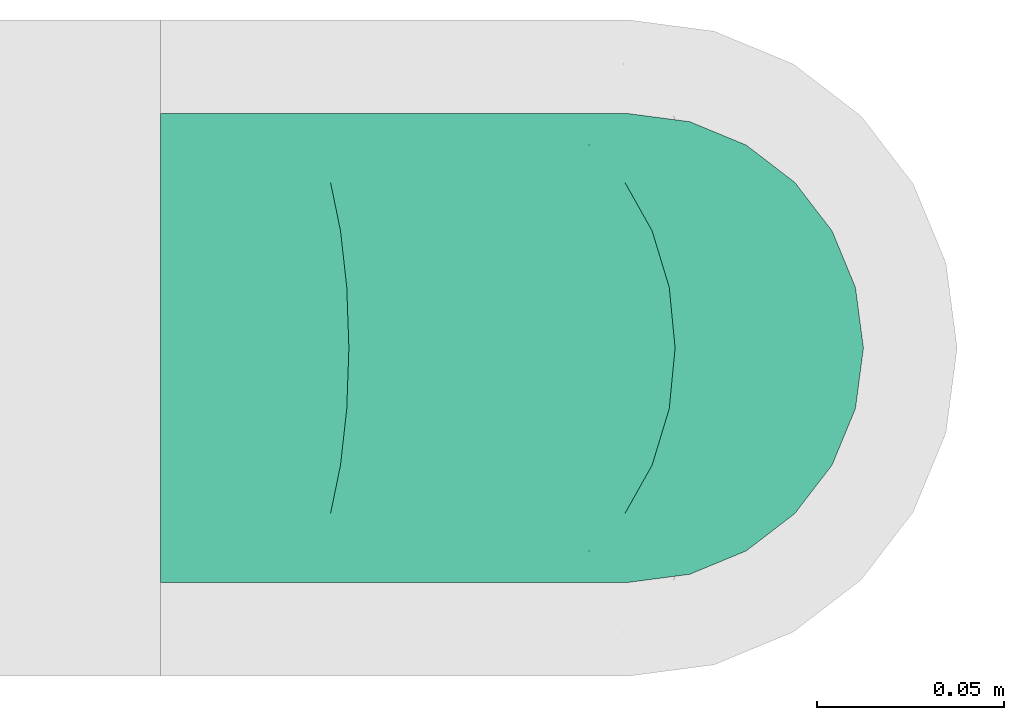
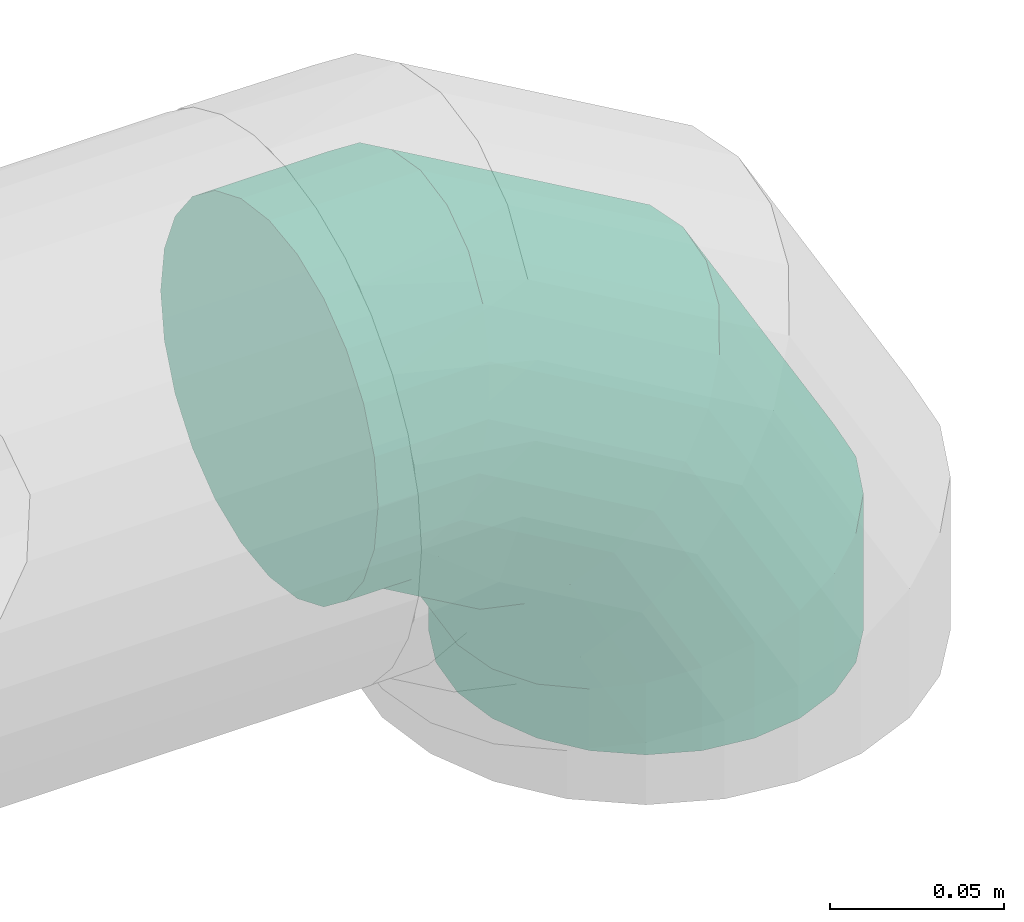
# One storey, part 84 of 97: 1 flow fitting.
"""IFC2X3 building model written with IfcOpenShell, lengths in millimetres."""

from ifc_helpers import new_model, entity, si_unit, converted_unit, derived_unit, direction, frame, origin, place, context, subcontext, project, spatial, faceted_brep, source, transform, mapped, material, type_object, type_shapes, element, save


model = new_model("IFC2X3")

# Units and contexts
model_context = context("Model", 3, precision=0.01, world=origin(), true_north=direction((6.12303176911189e-17, 1.0)))
body_context = subcontext(model_context, "Body", "Model", "MODEL_VIEW")
ifc_project = project(units=[si_unit("LENGTHUNIT", "METRE", prefix="MILLI"), si_unit("AREAUNIT", "SQUARE_METRE"), si_unit("VOLUMEUNIT", "CUBIC_METRE"), converted_unit("PLANEANGLEUNIT", "DEGREE", entity("IfcRatioMeasure", 0.0174532925199433), si_unit("PLANEANGLEUNIT", "RADIAN"), dimensions=[0, 0, 0, 0, 0, 0, 0]), si_unit("MASSUNIT", "GRAM", prefix="KILO"), derived_unit("MASSDENSITYUNIT", [(si_unit("MASSUNIT", "GRAM", prefix="KILO"), 1), (si_unit("LENGTHUNIT", "METRE"), -3)]), derived_unit("MOMENTOFINERTIAUNIT", [(si_unit("LENGTHUNIT", "METRE"), 4)]), si_unit("TIMEUNIT", "SECOND"), si_unit("FREQUENCYUNIT", "HERTZ"), si_unit("THERMODYNAMICTEMPERATUREUNIT", "DEGREE_CELSIUS"), derived_unit("THERMALTRANSMITTANCEUNIT", [(si_unit("MASSUNIT", "GRAM", prefix="KILO"), 1), (si_unit("THERMODYNAMICTEMPERATUREUNIT", "KELVIN"), -1), (si_unit("TIMEUNIT", "SECOND"), -3)]), derived_unit("VOLUMETRICFLOWRATEUNIT", [(si_unit("LENGTHUNIT", "METRE"), 3), (si_unit("TIMEUNIT", "SECOND"), -1)]), derived_unit("MASSFLOWRATEUNIT", [(si_unit("MASSUNIT", "GRAM", prefix="KILO"), 1), (si_unit("TIMEUNIT", "SECOND"), -1)]), derived_unit("ROTATIONALFREQUENCYUNIT", [(si_unit("TIMEUNIT", "SECOND"), -1)]), si_unit("ELECTRICCURRENTUNIT", "AMPERE"), si_unit("ELECTRICVOLTAGEUNIT", "VOLT"), si_unit("POWERUNIT", "WATT"), si_unit("FORCEUNIT", "NEWTON", prefix="KILO"), si_unit("ILLUMINANCEUNIT", "LUX"), si_unit("LUMINOUSFLUXUNIT", "LUMEN"), si_unit("LUMINOUSINTENSITYUNIT", "CANDELA"), derived_unit("USERDEFINED", [(si_unit("MASSUNIT", "GRAM", prefix="KILO"), -1), (si_unit("LENGTHUNIT", "METRE"), -2), (si_unit("TIMEUNIT", "SECOND"), 3), (si_unit("LUMINOUSFLUXUNIT", "LUMEN"), 1)]), derived_unit("LINEARVELOCITYUNIT", [(si_unit("LENGTHUNIT", "METRE"), 1), (si_unit("TIMEUNIT", "SECOND"), -1)]), si_unit("PRESSUREUNIT", "PASCAL"), derived_unit("USERDEFINED", [(si_unit("LENGTHUNIT", "METRE"), -2), (si_unit("MASSUNIT", "GRAM", prefix="KILO"), 1), (si_unit("TIMEUNIT", "SECOND"), -2)]), derived_unit("LINEARFORCEUNIT", [(si_unit("MASSUNIT", "GRAM", prefix="KILO"), 1), (si_unit("LENGTHUNIT", "METRE"), 1), (si_unit("TIMEUNIT", "SECOND"), -2), (si_unit("LENGTHUNIT", "METRE"), -1)]), derived_unit("PLANARFORCEUNIT", [(si_unit("MASSUNIT", "GRAM", prefix="KILO"), 1), (si_unit("LENGTHUNIT", "METRE"), 1), (si_unit("TIMEUNIT", "SECOND"), -2), (si_unit("LENGTHUNIT", "METRE"), -2)])], contexts=[model_context])

# Site, building, storey
site_placement = place(None, origin())
site = spatial("IfcSite", under=ifc_project, at=site_placement, CompositionType="ELEMENT")
building_placement = place(site_placement, origin())
building = spatial("IfcBuilding", under=site, at=building_placement, CompositionType="ELEMENT")
storey_placement = place(building_placement, frame((0.0, 0.0, -4900.0)))
storey = spatial("IfcBuildingStorey", under=building, at=storey_placement, CompositionType="ELEMENT", Elevation=-4900.0)

# Flow fitting
ifc_material = material()
duct_fitting_type = type_object("IfcDuctFittingType", PredefinedType="NOTDEFINED", material=ifc_material)
shared_shape = source(origin(), body_context, "Body", "Brep", [
    faceted_brep([(-125.0, 0.0, -62.5), (-125.0, -16.18, -60.37), (-125.0, -31.25, -54.13), (-125.0, -44.19, -44.19), (-125.0, -54.13, -31.25), (-125.0, -60.37, -16.18), (-125.0, -62.5, 0.0), (-125.0, -60.37, 16.18), (-125.0, -54.13, 31.25), (-125.0, -44.19, 44.19), (-125.0, -31.25, 54.13), (-125.0, -16.18, 60.37), (-125.0, 0.0, 62.5), (-125.0, 16.18, 60.37), (-125.0, 31.25, 54.13), (-125.0, 44.19, 44.19), (-125.0, 54.13, 31.25), (-125.0, 60.37, 16.18), (-125.0, 62.5, 0.0), (-125.0, 60.37, -16.18), (-125.0, 54.13, -31.25), (-125.0, 44.19, -44.19), (-125.0, 31.25, -54.13), (-125.0, 16.18, -60.37), (-95.84, 16.18, 60.37), (-99.88, 31.25, 54.13), (-91.51, 0.0, 62.5), (-103.35, 44.19, 44.19), (-107.68, 60.37, 16.18), (-108.25, 62.5, 0.0), (-106.01, 54.13, 31.25), (-106.01, 54.13, -31.25), (-103.35, 44.19, -44.19), (-107.68, 60.37, -16.18), (-95.84, 16.18, -60.37), (-91.51, 0.0, -62.5), (-99.88, 31.25, -54.13), (-87.17, -16.18, -60.37), (-83.13, -31.25, -54.13), (-79.66, -44.19, -44.19), (-77.0, -54.13, -31.25), (-75.33, -60.37, -16.18), (-74.76, -62.5, 0.0), (-75.33, -60.37, 16.18), (-77.0, -54.13, 31.25), (-79.66, -44.19, 44.19), (-83.13, -31.25, 54.13), (-87.17, -16.18, 60.37), (-45.34, 45.34, 60.37), (-56.37, 56.37, 54.13), (-33.49, 33.49, 62.5), (-65.85, 65.85, 44.19), (-73.12, 73.12, 31.25), (-77.69, 77.69, 16.18), (-79.25, 79.25, 0.0), (-77.69, 77.69, -16.18), (-73.12, 73.12, -31.25), (-65.85, 65.85, -44.19), (-45.34, 45.34, -60.37), (-33.49, 33.49, -62.5), (-56.37, 56.37, -54.13), (-21.65, 21.65, -60.37), (-10.62, 10.62, -54.13), (-1.14, 1.14, -44.19), (6.13, -6.13, -31.25), (10.7, -10.7, -16.18), (12.26, -12.26, 0.0), (10.7, -10.7, 16.18), (6.13, -6.13, 31.25), (-1.14, 1.14, 44.19), (-10.62, 10.62, 54.13), (-21.65, 21.65, 60.37), (-16.18, 95.84, 60.37), (-31.25, 99.88, 54.13), (0.0, 91.51, 62.5), (-44.19, 103.35, 44.19), (-54.13, 106.01, 31.25), (-60.37, 107.68, 16.18), (-62.5, 108.25, 0.0), (-60.37, 107.68, -16.18), (-54.13, 106.01, -31.25), (-44.19, 103.35, -44.19), (-16.18, 95.84, -60.37), (0.0, 91.51, -62.5), (-31.25, 99.88, -54.13), (16.18, 87.17, -60.37), (31.25, 83.13, -54.13), (44.19, 79.66, -44.19), (54.13, 77.0, -31.25), (60.37, 75.33, -16.18), (62.5, 74.76, 0.0), (60.37, 75.33, 16.18), (54.13, 77.0, 31.25), (44.19, 79.66, 44.19), (31.25, 83.13, 54.13), (16.18, 87.17, 60.37), (-16.18, 125.0, -60.37), (-31.25, 125.0, -54.13), (-44.19, 125.0, -44.19), (-54.13, 125.0, -31.25), (-60.37, 125.0, -16.18), (-62.5, 125.0, 0.0), (-60.37, 125.0, 16.18), (-54.13, 125.0, 31.25), (-44.19, 125.0, 44.19), (-31.25, 125.0, 54.13), (-16.18, 125.0, 60.37), (0.0, 125.0, 62.5), (16.18, 125.0, 60.37), (31.25, 125.0, 54.13), (44.19, 125.0, 44.19), (54.13, 125.0, 31.25), (60.37, 125.0, 16.18), (62.5, 125.0, 0.0), (60.37, 125.0, -16.18), (54.13, 125.0, -31.25), (44.19, 125.0, -44.19), (31.25, 125.0, -54.13), (16.18, 125.0, -60.37), (0.0, 125.0, -62.5)], [[[0, 1, 2, 3, 4, 5, 6, 7, 8, 9, 10, 11, 12, 13, 14, 15, 16, 17, 18, 19, 20, 21, 22, 23]], [[24, 25, 14, 13]], [[26, 24, 13, 12]], [[14, 25, 27, 15]], [[28, 29, 18, 17]], [[30, 28, 17, 16]], [[15, 27, 30, 16]], [[20, 31, 32, 21]], [[33, 31, 20, 19]], [[18, 29, 33, 19]], [[34, 35, 0, 23]], [[36, 34, 23, 22]], [[21, 32, 36, 22]], [[1, 0, 35, 37]], [[2, 1, 37, 38]], [[38, 39, 3, 2]], [[5, 4, 40, 41]], [[6, 5, 41, 42]], [[39, 40, 4, 3]], [[6, 42, 43, 7]], [[7, 43, 44, 8]], [[45, 9, 8, 44]], [[9, 45, 46, 10]], [[10, 46, 47, 11]], [[26, 12, 11, 47]], [[48, 49, 25, 24]], [[50, 48, 24, 26]], [[27, 25, 49, 51]], [[52, 53, 28, 30]], [[51, 52, 30, 27]], [[29, 28, 53, 54]], [[55, 56, 31, 33]], [[54, 55, 33, 29]], [[57, 32, 31, 56]], [[58, 59, 35, 34]], [[60, 58, 34, 36]], [[57, 60, 36, 32]], [[37, 35, 59, 61]], [[38, 37, 61, 62]], [[39, 38, 62, 63]], [[41, 40, 64, 65]], [[42, 41, 65, 66]], [[63, 64, 40, 39]], [[43, 42, 66, 67]], [[44, 43, 67, 68]], [[68, 69, 45, 44]], [[46, 45, 69, 70]], [[47, 46, 70, 71]], [[26, 47, 71, 50]], [[72, 73, 49, 48]], [[74, 72, 48, 50]], [[51, 49, 73, 75]], [[76, 77, 53, 52]], [[75, 76, 52, 51]], [[54, 53, 77, 78]], [[79, 80, 56, 55]], [[78, 79, 55, 54]], [[81, 57, 56, 80]], [[82, 83, 59, 58]], [[84, 82, 58, 60]], [[81, 84, 60, 57]], [[61, 59, 83, 85]], [[62, 61, 85, 86]], [[63, 62, 86, 87]], [[65, 64, 88, 89]], [[66, 65, 89, 90]], [[87, 88, 64, 63]], [[67, 66, 90, 91]], [[68, 67, 91, 92]], [[92, 93, 69, 68]], [[70, 69, 93, 94]], [[71, 70, 94, 95]], [[50, 71, 95, 74]], [[96, 97, 98, 99, 100, 101, 102, 103, 104, 105, 106, 107, 108, 109, 110, 111, 112, 113, 114, 115, 116, 117, 118, 119]], [[72, 74, 107, 106]], [[73, 72, 106, 105]], [[75, 73, 105, 104]], [[77, 76, 103, 102]], [[78, 77, 102, 101]], [[75, 104, 103, 76]], [[78, 101, 100, 79]], [[79, 100, 99, 80]], [[80, 99, 98, 81]], [[96, 119, 83, 82]], [[97, 96, 82, 84]], [[84, 81, 98, 97]], [[83, 119, 118, 85]], [[85, 118, 117, 86]], [[116, 87, 86, 117]], [[88, 115, 114, 89]], [[89, 114, 113, 90]], [[115, 88, 87, 116]], [[91, 90, 113, 112]], [[92, 91, 112, 111]], [[111, 110, 93, 92]], [[95, 94, 109, 108]], [[74, 95, 108, 107]], [[110, 109, 94, 93]]]),
])
type_shapes(duct_fitting_type, [shared_shape])
flow_fitting_placement = place(storey_placement, frame((71148.65, 18883.31, 4000.0), z_axis=(0.0, -1.0, 0.0), x_axis=(0.0, 0.0, 1.0)))
element("IfcFlowFitting", 1, at=flow_fitting_placement, inside=storey, type_object=duct_fitting_type, material=ifc_material, context=body_context, shape_type="MappedRepresentation", body=[
    mapped(shared_shape, transform((0.0, 0.0, 0.0), scale=1.0)),
])

save(model, "model.ifc")
